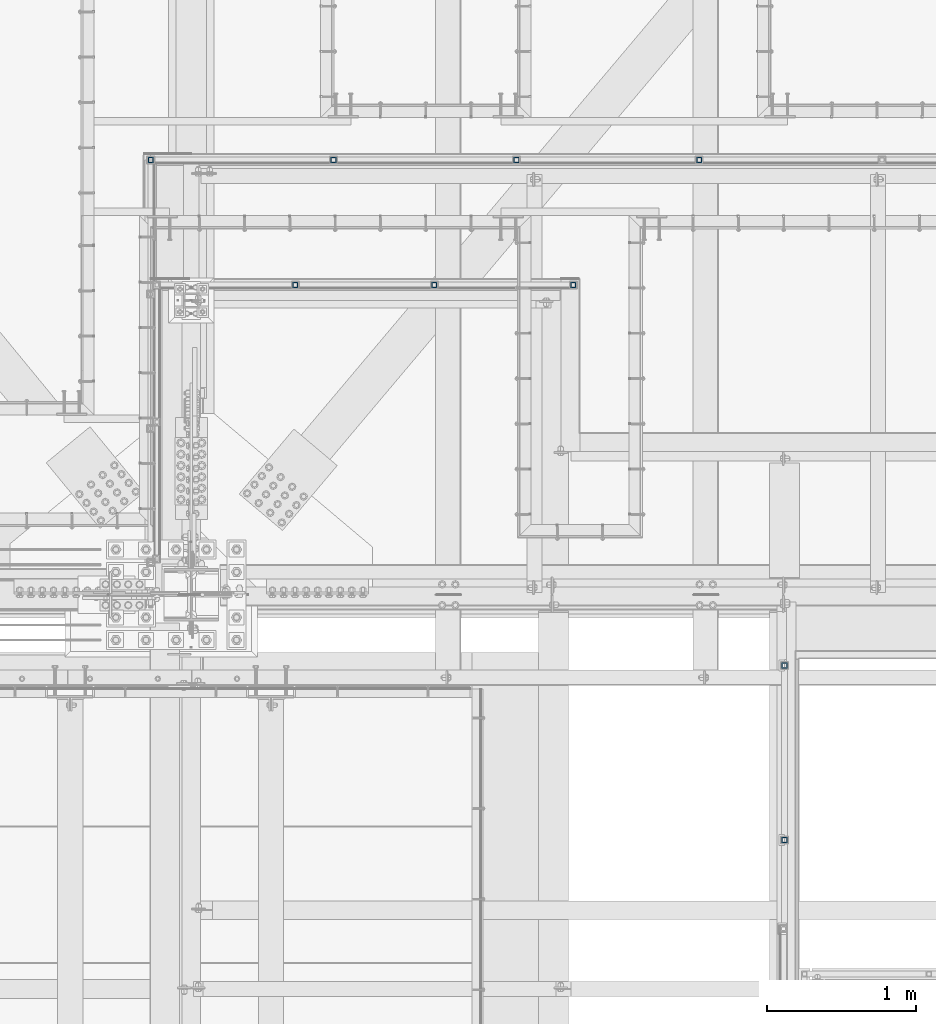
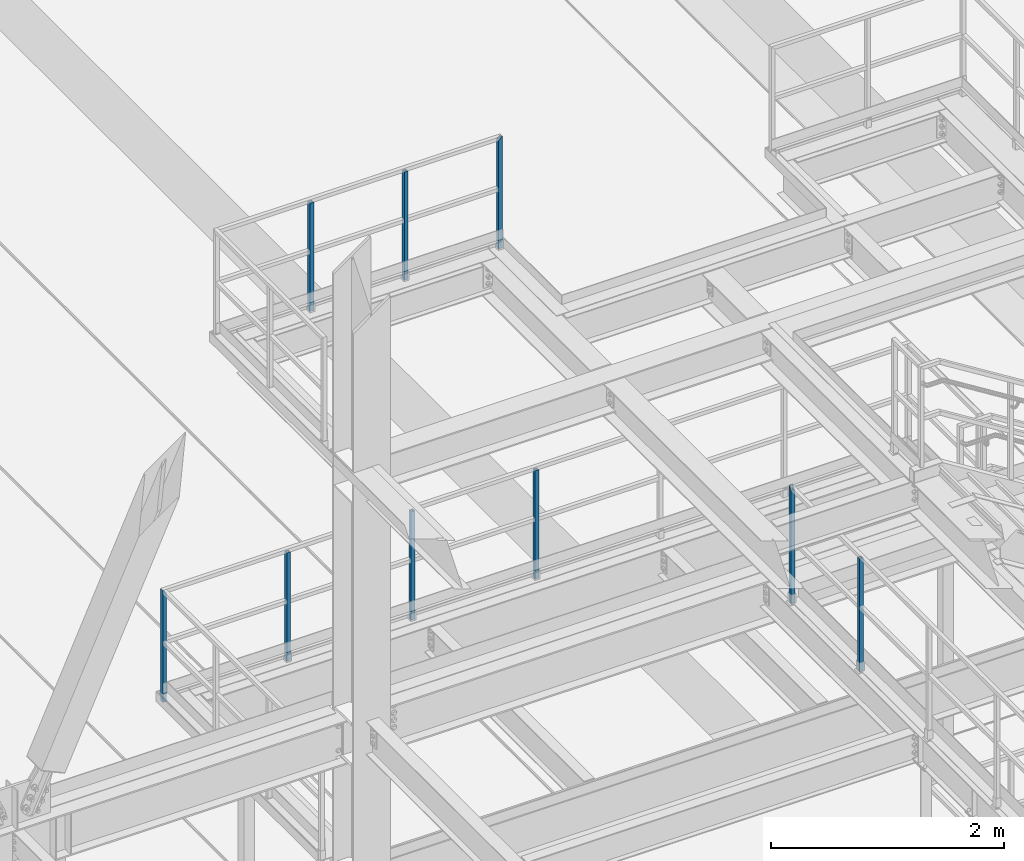
# One storey, part 1303 of 3843: 9 columns, 3 elements without a shape of their own.
"""IFC2X3 building model written with IfcOpenShell, lengths in millimetres."""

import ifcopenshell
import ifcopenshell.guid

model = None  # the IFC model being written
_history = None  # IfcOwnerHistory: only IFC2X3 demands one
_inside = {}  # id of a spatial element -> (the spatial element, [elements in it])
_under = {}  # id of a project, library or spatial element -> (it, [spatial elements below it])
_declared = {}  # id of a project -> (the project, [libraries it declares])
_typed = {}  # id of a type object -> (the type object, [elements of that type])
_made_of = {}  # id of a material, layer set ... -> (it, [elements and type objects made of it])


def new_model(schema):
    """Start an empty IFC model of exactly this schema.

    Asked for "IFC4X3", IfcOpenShell would pick the latest addendum, in which some entities
    have other attributes; the version numbers below select the first issue.
    IFC2X3 requires an IfcOwnerHistory on every rooted entity: one is made here for all.
    """
    global model, _history
    if schema == "IFC4X3":
        model = ifcopenshell.file(schema_version=(4, 3, 0, 0))
    else:
        model = ifcopenshell.file(schema=schema)
    _inside.clear()
    _under.clear()
    _declared.clear()
    _typed.clear()
    _made_of.clear()
    _history = None
    if model.schema == "IFC2X3":
        org = make("IfcOrganization", Name="unknown")
        user = make(
            "IfcPersonAndOrganization",
            ThePerson=make("IfcPerson", FamilyName="unknown"),
            TheOrganization=org,
        )
        app = make(
            "IfcApplication",
            ApplicationDeveloper=org,
            Version="unknown",
            ApplicationFullName="unknown",
            ApplicationIdentifier="unknown",
        )
        _history = make(
            "IfcOwnerHistory",
            OwningUser=user,
            OwningApplication=app,
            ChangeAction="ADDED",
            CreationDate=0,
        )
    return model


def make(cls, **values):
    """One entity of the class cls with the attributes given. An attribute that is None is left unset."""
    return model.create_entity(
        cls, **{name: value for name, value in values.items() if value is not None}
    )


def rooted(cls, **values):
    """An entity with a GlobalId (a new one), such as an element, a storey or a relation."""
    return make(cls, GlobalId=ifcopenshell.guid.new(), OwnerHistory=_history, **values)


def si_unit(unit_type, name, prefix=None):
    """IfcSIUnit, for example si_unit("LENGTHUNIT", "METRE", prefix="MILLI")."""
    return make("IfcSIUnit", UnitType=unit_type, Prefix=prefix, Name=name)


def assignment(units):
    """IfcUnitAssignment: the units of a project."""
    return None if units is None else make("IfcUnitAssignment", Units=units)


def point(xyz):
    """IfcCartesianPoint."""
    return None if xyz is None else make("IfcCartesianPoint", Coordinates=xyz)


def direction(xyz):
    """IfcDirection."""
    return None if xyz is None else make("IfcDirection", DirectionRatios=xyz)


def frame(location, z_axis=None, x_axis=None):
    """IfcAxis2Placement3D, a coordinate frame: its origin and axes. An axis left out is left unset."""
    return make(
        "IfcAxis2Placement3D",
        Location=point(location),
        Axis=direction(z_axis),
        RefDirection=direction(x_axis),
    )


def origin_with_axes():
    """The frame at (0, 0, 0) with the z axis (0, 0, 1) and the x axis (1, 0, 0) written out."""
    return frame((0.0, 0.0, 0.0), z_axis=(0.0, 0.0, 1.0), x_axis=(1.0, 0.0, 0.0))


def place(relative_to, where):
    """IfcLocalPlacement: puts the frame where relative to a parent placement (None: the world)."""
    return make(
        "IfcLocalPlacement", PlacementRelTo=relative_to, RelativePlacement=where
    )


def context(
    kind, dimensions, precision=None, world=None, true_north=None, identifier=None
):
    """IfcGeometricRepresentationContext, for example the 3D "Model" context."""
    return make(
        "IfcGeometricRepresentationContext",
        ContextIdentifier=identifier,
        ContextType=kind,
        CoordinateSpaceDimension=dimensions,
        Precision=precision,
        WorldCoordinateSystem=world,
        TrueNorth=true_north,
    )


def subcontext(parent, identifier, kind, view, scale=None):
    """IfcGeometricRepresentationSubContext, for example "Body" below "Model"."""
    return make(
        "IfcGeometricRepresentationSubContext",
        ContextIdentifier=identifier,
        ContextType=kind,
        ParentContext=parent,
        TargetScale=scale,
        TargetView=view,
    )


def project(units=None, contexts=None):
    """IfcProject with its units and contexts."""
    return rooted(
        "IfcProject",
        Name="project",
        RepresentationContexts=contexts,
        UnitsInContext=assignment(units),
    )


def spatial(cls, under=None, at=None, **own):
    """A site, building, storey or space (cls), placed at a placement, below another one or the project."""
    s = rooted(cls, ObjectPlacement=at, **own)
    if under is not None:
        _under.setdefault(under.id(), (under, []))[1].append(s)
    return s


def faces_of(points, faces, orient=None, outer=None):
    """IfcFace entities. A face is a list of loops; a loop is a list of indices into points, from 0.

    orient and outer hold one flag for each loop. By default every Orientation is true, the
    first loop of a face is its IfcFaceOuterBound and the others are IfcFaceBound.
    """
    made = []
    for i, loops in enumerate(faces):
        bounds = []
        for j, loop in enumerate(loops):
            is_outer = j == 0 if outer is None else outer[i][j]
            bounds.append(
                make(
                    "IfcFaceOuterBound" if is_outer else "IfcFaceBound",
                    Bound=make("IfcPolyLoop", Polygon=[points[k] for k in loop]),
                    Orientation=True if orient is None else orient[i][j],
                )
            )
        made.append(make("IfcFace", Bounds=bounds))
    return made


def faceted_brep(points, faces, orient=None, outer=None, voids=None):
    """IfcFacetedBrep: a solid bounded by flat faces; with voids (closed shells), ...WithVoids."""
    shared = [point(p) for p in points]
    hull = make("IfcClosedShell", CfsFaces=faces_of(shared, faces, orient, outer))
    if voids is None:
        return make("IfcFacetedBrep", Outer=hull)
    return make(
        "IfcFacetedBrepWithVoids",
        Outer=hull,
        Voids=[
            make(cls, CfsFaces=faces_of(shared, fs, o, b)) for cls, fs, o, b in voids
        ],
    )


def shape(context_of_items, identifier, shape_type, items):
    """IfcShapeRepresentation: the items that make up one representation, for example the "Body"."""
    return make(
        "IfcShapeRepresentation",
        ContextOfItems=context_of_items,
        RepresentationIdentifier=identifier,
        RepresentationType=shape_type,
        Items=items,
    )


def material(Name=None, Category=None):
    """IfcMaterial."""
    return make("IfcMaterial", Name=Name, Category=Category)


def made_of(thing, what):
    """Note that an element or type object is made of a material, layer set ...; save() writes the relation."""
    if what is not None:
        _made_of.setdefault(what.id(), (what, []))[1].append(thing)
    return thing


def type_object(cls, material=None, **own):
    """A type object (cls), such as IfcWallType, which elements share."""
    return made_of(rooted(cls, **own), material)


def element(
    cls,
    number,
    at=None,
    inside=None,
    cuts=None,
    type_object=None,
    material=None,
    context=None,
    identifier="Body",
    shape_type=None,
    held_by="IfcProductDefinitionShape",
    body=None,
    shapes=None,
    **own,
):
    """One element of the class cls, such as IfcWall. Its Tag is "e" and its number.

    at: its placement. inside: the storey or other place that contains it. cuts: it is an
    opening in that element (IfcRelVoidsElement). A single representation is given by context,
    identifier, shape_type and body (its items); several are given by shapes. held_by: the class
    of the entity that holds the representations. save() writes the other relations.
    """
    e = rooted(cls, Tag="e%d" % number, ObjectPlacement=at, **own)
    if body is not None:
        shapes = [shape(context, identifier, shape_type, body)]
    if shapes is not None:
        e.Representation = make(held_by, Representations=shapes)
    if inside is not None:
        _inside.setdefault(inside.id(), (inside, []))[1].append(e)
    if cuts is not None:
        rooted(
            "IfcRelVoidsElement", RelatingBuildingElement=cuts, RelatedOpeningElement=e
        )
    if type_object is not None:
        _typed.setdefault(type_object.id(), (type_object, []))[1].append(e)
    return made_of(e, material)


def aggregate(whole, parts):
    """IfcRelAggregates: a whole, such as a stair, and the parts it consists of."""
    return rooted("IfcRelAggregates", RelatingObject=whole, RelatedObjects=parts)


def save(model, path):
    """Write the relations noted so far, then the file.

    IfcRelAggregates (storeys below a building ...), IfcRelContainedInSpatialStructure (elements
    in a storey), IfcRelDefinesByType, IfcRelAssociatesMaterial and IfcRelDeclares: one each for
    every whole, place, type object, material and project.
    """
    for whole, parts in _under.values():
        aggregate(whole, parts)
    for where, things in _inside.values():
        rooted(
            "IfcRelContainedInSpatialStructure",
            RelatedElements=things,
            RelatingStructure=where,
        )
    for kind, things in _typed.values():
        rooted("IfcRelDefinesByType", RelatedObjects=things, RelatingType=kind)
    for what, things in _made_of.values():
        rooted("IfcRelAssociatesMaterial", RelatedObjects=things, RelatingMaterial=what)
    for by, libraries in _declared.values():
        rooted("IfcRelDeclares", RelatingContext=by, RelatedDefinitions=libraries)
    model.write(path)


model = new_model("IFC2X3")

# Units and contexts
model_context = context("Model", 3, precision=1e-05, world=origin_with_axes())
body_context = subcontext(model_context, "Body", "Model", "MODEL_VIEW")
ifc_project = project(units=[si_unit("LENGTHUNIT", "METRE", prefix="MILLI"), si_unit("AREAUNIT", "SQUARE_METRE"), si_unit("VOLUMEUNIT", "CUBIC_METRE"), si_unit("MASSUNIT", "GRAM", prefix="KILO"), si_unit("TIMEUNIT", "SECOND"), si_unit("PLANEANGLEUNIT", "RADIAN"), si_unit("SOLIDANGLEUNIT", "STERADIAN"), si_unit("THERMODYNAMICTEMPERATUREUNIT", "DEGREE_CELSIUS"), si_unit("LUMINOUSINTENSITYUNIT", "LUMEN")], contexts=[model_context])

# Site, building, storey
site_placement = place(None, origin_with_axes())
site = spatial("IfcSite", under=ifc_project, at=site_placement, CompositionType="ELEMENT")
building_placement = place(site_placement, origin_with_axes())
building = spatial("IfcBuilding", under=site, at=building_placement, Name="Undefined", CompositionType="ELEMENT")
storey_placement = place(building_placement, origin_with_axes())
storey = spatial("IfcBuildingStorey", under=building, at=storey_placement, Name="Undefined", CompositionType="ELEMENT", Elevation=0.0)

# Assembly, columns
assembly_1_placement = place(storey_placement, origin_with_axes())
assembly_1 = element("IfcElementAssembly", 1, at=assembly_1_placement, inside=storey, Name="RAIL", AssemblyPlace="NOTDEFINED", PredefinedType="RIGID_FRAME")
ifc_material = material()
column_type = type_object("IfcColumnType", Name="HSS1-1/2X1-1/2X1/4", PredefinedType="NOTDEFINED")
column_1_placement = place(assembly_1_placement, frame((52990.75, 23964.8999998087, 34817.05), z_axis=(0.0, 1.0, 0.0), x_axis=(0.0, 0.0, 1.0)))
column_1 = element("IfcColumn", 2, at=column_1_placement, type_object=column_type, material=ifc_material, Name="POST", ObjectType="HSS1-1/2X1-1/2X1/4", context=body_context, shape_type="Brep", body=[
    faceted_brep([(0.0, 12.6999993299978, -12.6999993300014), (0.0, -12.6999993299978, -12.6999993300014), (1181.09999694864, -12.6999993299978, -12.6999993300014), (1181.09999694864, 12.6999993299978, -12.6999993300014), (0.0, -12.6999993299978, 12.6999993300014), (1181.09999694864, -12.6999993299978, 12.6999993300014), (0.0, 12.6999993299978, 12.6999993300014), (1181.09999694864, 12.6999993299978, 12.6999993300014), (0.0, 19.0500000000029, -19.0499999999993), (0.0, 19.0499992350015, 19.0499992350015), (1181.09999694864, 19.0499992350015, 19.0499992350015), (1181.09999694864, 19.0499992350015, -19.0499992350015), (0.0, -19.0499992350015, 19.0499992350015), (1181.09999694864, -19.0499992350015, 19.0499992350015), (0.0, -19.0499992350015, -19.0499992350015), (1181.09999694864, -19.0499992350015, -19.0499992350015)], [[[0, 1, 2, 3]], [[1, 4, 5, 2]], [[4, 6, 7, 5]], [[6, 0, 3, 7]], [[8, 9, 10, 11]], [[9, 12, 13, 10]], [[12, 14, 15, 13]], [[14, 8, 11, 15]], [[13, 15, 11, 10], [5, 7, 3, 2]], [[14, 12, 9, 8], [6, 4, 1, 0]]]),
])
column_2_placement = place(assembly_1_placement, frame((52990.75, 25139.65, 34817.05), z_axis=(0.0, 1.0, 0.0), x_axis=(0.0, 0.0, 1.0)))
column_2 = element("IfcColumn", 3, at=column_2_placement, type_object=column_type, material=ifc_material, Name="POST", ObjectType="HSS1-1/2X1-1/2X1/4", context=body_context, shape_type="Brep", body=[
    faceted_brep([(0.0, 12.6999993299978, -12.6999993300014), (0.0, -12.6999993299978, -12.6999993300014), (1187.44999761864, -12.6999993299978, -12.6999993300014), (1187.44999761864, 12.6999993299978, -12.6999993300014), (0.0, -12.6999993299978, 12.6999993300014), (1212.84999627864, -12.6999993299978, 12.6999993300014), (0.0, 12.6999993299978, 12.6999993300014), (1212.84999627864, 12.6999993299978, 12.6999993300014), (0.0, 19.0500000000029, -19.0499999999993), (0.0, 19.0499992350015, 19.0499992350015), (1219.19999618364, 19.0499992350015, 19.0499992350015), (1181.09999694864, 19.0499992350015, -19.0499992350015), (0.0, -19.0499992350015, 19.0499992350015), (1219.19999618364, -19.0499992350015, 19.0499992350015), (0.0, -19.0499992350015, -19.0499992350015), (1181.09999694864, -19.0499992350015, -19.0499992350015)], [[[0, 1, 2, 3]], [[1, 4, 5, 2]], [[4, 6, 7, 5]], [[6, 0, 3, 7]], [[8, 9, 10, 11]], [[9, 12, 13, 10]], [[12, 14, 15, 13]], [[14, 8, 11, 15]], [[13, 15, 11, 10], [5, 7, 3, 2]], [[14, 12, 9, 8], [6, 4, 1, 0]]]),
])
aggregate(assembly_1, [column_1, column_2])

assembly_2_placement = place(storey_placement, origin_with_axes())
assembly_2 = element("IfcElementAssembly", 4, at=assembly_2_placement, inside=storey, Name="RAIL", AssemblyPlace="NOTDEFINED", PredefinedType="RIGID_FRAME")
column_3_placement = place(assembly_2_placement, frame((50632.7833312988, 27701.8747862042, 37566.5999983552), z_axis=(-1.0, 0.0, 0.0), x_axis=(0.0, 0.0, 1.0)))
column_3 = element("IfcColumn", 5, at=column_3_placement, type_object=column_type, material=ifc_material, Name="POST", ObjectType="HSS1-1/2X1-1/2X1/4", context=body_context, shape_type="Brep", body=[
    faceted_brep([(-88.8999998754371, 12.6999993300014, -12.6999993299978), (-88.8999998754371, -12.6999993300014, -12.6999993299978), (1047.75000076497, -12.6999993300014, -12.6999993299978), (1047.75000076497, 12.6999993300014, -12.6999993299978), (-88.8999998754371, -12.6999993300014, 12.6999993299978), (1047.75000076497, -12.6999993300014, 12.6999993299978), (-88.8999998754371, 12.6999993300014, 12.6999993299978), (1047.75000076497, 12.6999993300014, 12.6999993299978), (-88.8999998754371, 19.0499992350015, -19.0499992350015), (-88.8999998754371, 19.0499992350015, 19.0499992350015), (1047.75000076629, 19.0499992350015, 19.0499992349942), (1047.750000765, 19.0499992350015, -19.0499992350015), (-88.8999998754371, -19.0499992350015, 19.0499992350015), (1047.75000076629, -19.0499992350015, 19.0499992349942), (-88.8999998754371, -19.0499992350015, -19.0499992350015), (1047.750000765, -19.0499992350015, -19.0499992350015)], [[[0, 1, 2, 3]], [[1, 4, 5, 2]], [[4, 6, 7, 5]], [[6, 0, 3, 7]], [[8, 9, 10, 11]], [[9, 12, 13, 10]], [[12, 14, 15, 13]], [[14, 8, 11, 15]], [[13, 15, 11, 10], [5, 7, 3, 2]], [[14, 12, 9, 8], [6, 4, 1, 0]]]),
])
column_4_placement = place(assembly_2_placement, frame((49697.2166595459, 27701.8747862042, 37566.5999983585), z_axis=(-1.0, 0.0, 0.0), x_axis=(0.0, 0.0, 1.0)))
column_4 = element("IfcColumn", 6, at=column_4_placement, type_object=column_type, material=ifc_material, Name="POST", ObjectType="HSS1-1/2X1-1/2X1/4", context=body_context, shape_type="Brep", body=[
    faceted_brep([(-88.8999998754371, 12.6999993300014, -12.6999993299978), (-88.8999998754371, -12.6999993300014, -12.6999993299978), (1047.75000076497, -12.6999993300014, -12.6999993299978), (1047.75000076497, 12.6999993300014, -12.6999993299978), (-88.8999998754371, -12.6999993300014, 12.6999993299978), (1047.75000076497, -12.6999993300014, 12.6999993299978), (-88.8999998754371, 12.6999993300014, 12.6999993299978), (1047.75000076497, 12.6999993300014, 12.6999993299978), (-88.8999998754371, 19.0499992350015, -19.0499992350015), (-88.8999998754371, 19.0499992350015, 19.0499992350015), (1047.75000076629, 19.0499992350015, 19.0499992349942), (1047.750000765, 19.0499992350015, -19.0499992350015), (-88.8999998754371, -19.0499992350015, 19.0499992350015), (1047.75000076629, -19.0499992350015, 19.0499992349942), (-88.8999998754371, -19.0499992350015, -19.0499992350015), (1047.750000765, -19.0499992350015, -19.0499992350015)], [[[0, 1, 2, 3]], [[1, 4, 5, 2]], [[4, 6, 7, 5]], [[6, 0, 3, 7]], [[8, 9, 10, 11]], [[9, 12, 13, 10]], [[12, 14, 15, 13]], [[14, 8, 11, 15]], [[13, 15, 11, 10], [5, 7, 3, 2]], [[14, 12, 9, 8], [6, 4, 1, 0]]]),
])
column_5_placement = place(assembly_2_placement, frame((51568.3500030518, 27701.8747862042, 37566.5999983618), z_axis=(-1.0, 0.0, 0.0), x_axis=(0.0, 0.0, 1.0)))
column_5 = element("IfcColumn", 7, at=column_5_placement, type_object=column_type, material=ifc_material, Name="POST", ObjectType="HSS1-1/2X1-1/2X1/4", context=body_context, shape_type="Brep", body=[
    faceted_brep([(-88.8999998754371, 12.6999993300014, -12.6999993299978), (-88.8999998754371, -12.6999993300014, -12.6999993299978), (1079.49999933128, -12.6999993300014, -12.6999993299978), (1079.49999933128, 12.6999993300014, -12.6999993299978), (-88.8999998754371, -12.6999993300014, 12.6999993299978), (1054.10000067129, -12.6999993300014, 12.6999993299978), (-88.8999998754371, 12.6999993300014, 12.6999993299978), (1054.10000067129, 12.6999993300014, 12.6999993299978), (-88.8999998754371, 19.0499992350015, -19.0499992350015), (-88.8999998754371, 19.0499992350015, 19.0499992350015), (1047.75000076629, 19.0499992350015, 19.0499992349942), (1085.84999923629, 19.0499992350015, -19.0499992349942), (-88.8999998754371, -19.0499992350015, 19.0499992350015), (1047.75000076629, -19.0499992350015, 19.0499992349942), (-88.8999998754371, -19.0499992350015, -19.0499992350015), (1085.84999923629, -19.0499992350015, -19.0499992349942)], [[[0, 1, 2, 3]], [[1, 4, 5, 2]], [[4, 6, 7, 5]], [[6, 0, 3, 7]], [[8, 9, 10, 11]], [[9, 12, 13, 10]], [[12, 14, 15, 13]], [[14, 8, 11, 15]], [[13, 15, 11, 10], [5, 7, 3, 2]], [[14, 12, 9, 8], [6, 4, 1, 0]]]),
])
aggregate(assembly_2, [column_3, column_4, column_5])

assembly_3_placement = place(storey_placement, origin_with_axes())
assembly_3 = element("IfcElementAssembly", 8, at=assembly_3_placement, inside=storey, Name="RAIL", AssemblyPlace="NOTDEFINED", PredefinedType="RIGID_FRAME")
column_6_placement = place(assembly_3_placement, frame((49954.3916666373, 28543.25, 33299.4000002631), z_axis=(1.0, 0.0, 0.0), x_axis=(0.0, 0.0, 1.0)))
column_6 = element("IfcColumn", 9, at=column_6_placement, type_object=column_type, material=ifc_material, Name="POST", ObjectType="HSS1-1/2X1-1/2X1/4", context=body_context, shape_type="Brep", body=[
    faceted_brep([(-88.8999998754371, 12.6999993300014, -12.6999993299978), (-88.8999998754371, -12.6999993300014, -12.6999993299978), (1047.75000076497, -12.6999993300014, -12.6999993299978), (1047.75000076497, 12.6999993300014, -12.6999993299978), (-88.8999998754371, -12.6999993300014, 12.6999993299978), (1047.75000076497, -12.6999993300014, 12.6999993299978), (-88.8999998754371, 12.6999993300014, 12.6999993299978), (1047.75000076497, 12.6999993300014, 12.6999993299978), (-88.8999998754371, 19.0499992350015, -19.0499992350015), (-88.8999998754371, 19.0499992350015, 19.0499992350015), (1047.75000076629, 19.0499992350015, 19.0499992349942), (1047.750000765, 19.0499992350015, -19.0499992350015), (-88.8999998754371, -19.0499992350015, 19.0499992350015), (1047.75000076629, -19.0499992350015, 19.0499992349942), (-88.8999998754371, -19.0499992350015, -19.0499992350015), (1047.750000765, -19.0499992350015, -19.0499992350015)], [[[0, 1, 2, 3]], [[1, 4, 5, 2]], [[4, 6, 7, 5]], [[6, 0, 3, 7]], [[8, 9, 10, 11]], [[9, 12, 13, 10]], [[12, 14, 15, 13]], [[14, 8, 11, 15]], [[13, 15, 11, 10], [5, 7, 3, 2]], [[14, 12, 9, 8], [6, 4, 1, 0]]]),
])
column_7_placement = place(assembly_3_placement, frame((51185.2333332985, 28543.25, 33299.4000002631), z_axis=(1.0, 0.0, 0.0), x_axis=(0.0, 0.0, 1.0)))
column_7 = element("IfcColumn", 10, at=column_7_placement, type_object=column_type, material=ifc_material, Name="POST", ObjectType="HSS1-1/2X1-1/2X1/4", context=body_context, shape_type="Brep", body=[
    faceted_brep([(-88.8999998754371, 12.6999993300014, -12.6999993299978), (-88.8999998754371, -12.6999993300014, -12.6999993299978), (1047.75000076497, -12.6999993300014, -12.6999993299978), (1047.75000076497, 12.6999993300014, -12.6999993299978), (-88.8999998754371, -12.6999993300014, 12.6999993299978), (1047.75000076497, -12.6999993300014, 12.6999993299978), (-88.8999998754371, 12.6999993300014, 12.6999993299978), (1047.75000076497, 12.6999993300014, 12.6999993299978), (-88.8999998754371, 19.0499992350015, -19.0499992350015), (-88.8999998754371, 19.0499992350015, 19.0499992350015), (1047.75000076629, 19.0499992350015, 19.0499992349942), (1047.750000765, 19.0499992350015, -19.0499992350015), (-88.8999998754371, -19.0499992350015, 19.0499992350015), (1047.75000076629, -19.0499992350015, 19.0499992349942), (-88.8999998754371, -19.0499992350015, -19.0499992350015), (1047.750000765, -19.0499992350015, -19.0499992350015)], [[[0, 1, 2, 3]], [[1, 4, 5, 2]], [[4, 6, 7, 5]], [[6, 0, 3, 7]], [[8, 9, 10, 11]], [[9, 12, 13, 10]], [[12, 14, 15, 13]], [[14, 8, 11, 15]], [[13, 15, 11, 10], [5, 7, 3, 2]], [[14, 12, 9, 8], [6, 4, 1, 0]]]),
])
column_8_placement = place(assembly_3_placement, frame((52416.0749999598, 28543.25, 33299.4000002631), z_axis=(1.0, 0.0, 0.0), x_axis=(0.0, 0.0, 1.0)))
column_8 = element("IfcColumn", 11, at=column_8_placement, type_object=column_type, material=ifc_material, Name="POST", ObjectType="HSS1-1/2X1-1/2X1/4", context=body_context, shape_type="Brep", body=[
    faceted_brep([(-88.8999998754371, 12.6999993300014, -12.6999993299978), (-88.8999998754371, -12.6999993300014, -12.6999993299978), (1047.75000076497, -12.6999993300014, -12.6999993299978), (1047.75000076497, 12.6999993300014, -12.6999993299978), (-88.8999998754371, -12.6999993300014, 12.6999993299978), (1047.75000076497, -12.6999993300014, 12.6999993299978), (-88.8999998754371, 12.6999993300014, 12.6999993299978), (1047.75000076497, 12.6999993300014, 12.6999993299978), (-88.8999998754371, 19.0499992350015, -19.0499992350015), (-88.8999998754371, 19.0499992350015, 19.0499992350015), (1047.75000076629, 19.0499992350015, 19.0499992349942), (1047.750000765, 19.0499992350015, -19.0499992350015), (-88.8999998754371, -19.0499992350015, 19.0499992350015), (1047.75000076629, -19.0499992350015, 19.0499992349942), (-88.8999998754371, -19.0499992350015, -19.0499992350015), (1047.750000765, -19.0499992350015, -19.0499992350015)], [[[0, 1, 2, 3]], [[1, 4, 5, 2]], [[4, 6, 7, 5]], [[6, 0, 3, 7]], [[8, 9, 10, 11]], [[9, 12, 13, 10]], [[12, 14, 15, 13]], [[14, 8, 11, 15]], [[13, 15, 11, 10], [5, 7, 3, 2]], [[14, 12, 9, 8], [6, 4, 1, 0]]]),
])
column_9_placement = place(assembly_3_placement, frame((48723.549999976, 28543.25, 33299.4000002631), z_axis=(1.0, 0.0, 0.0), x_axis=(0.0, 0.0, 1.0)))
column_9 = element("IfcColumn", 12, at=column_9_placement, type_object=column_type, material=ifc_material, Name="POST", ObjectType="HSS1-1/2X1-1/2X1/4", context=body_context, shape_type="Brep", body=[
    faceted_brep([(-88.8999998754371, 12.6999993300014, -12.6999993299978), (-88.8999998754371, -12.6999993300014, -12.6999993299978), (1079.49999933128, -12.6999993300014, -12.6999993299978), (1079.49999933128, 12.6999993300014, -12.6999993299978), (-88.8999998754371, -12.6999993300014, 12.6999993299978), (1054.10000067129, -12.6999993300014, 12.6999993299978), (-88.8999998754371, 12.6999993300014, 12.6999993299978), (1054.10000067129, 12.6999993300014, 12.6999993299978), (-88.8999998754371, 19.0499992350015, -19.0499992350015), (-88.8999998754371, 19.0499992350015, 19.0499992350015), (1047.75000076629, 19.0499992350015, 19.0499992349942), (1085.84999923629, 19.0499992350015, -19.0499992349942), (-88.8999998754371, -19.0499992350015, 19.0499992350015), (1047.75000076629, -19.0499992350015, 19.0499992349942), (-88.8999998754371, -19.0499992350015, -19.0499992350015), (1085.84999923629, -19.0499992350015, -19.0499992349942)], [[[0, 1, 2, 3]], [[1, 4, 5, 2]], [[4, 6, 7, 5]], [[6, 0, 3, 7]], [[8, 9, 10, 11]], [[9, 12, 13, 10]], [[12, 14, 15, 13]], [[14, 8, 11, 15]], [[13, 15, 11, 10], [5, 7, 3, 2]], [[14, 12, 9, 8], [6, 4, 1, 0]]]),
])
aggregate(assembly_3, [column_6, column_7, column_8, column_9])

save(model, "model.ifc")
